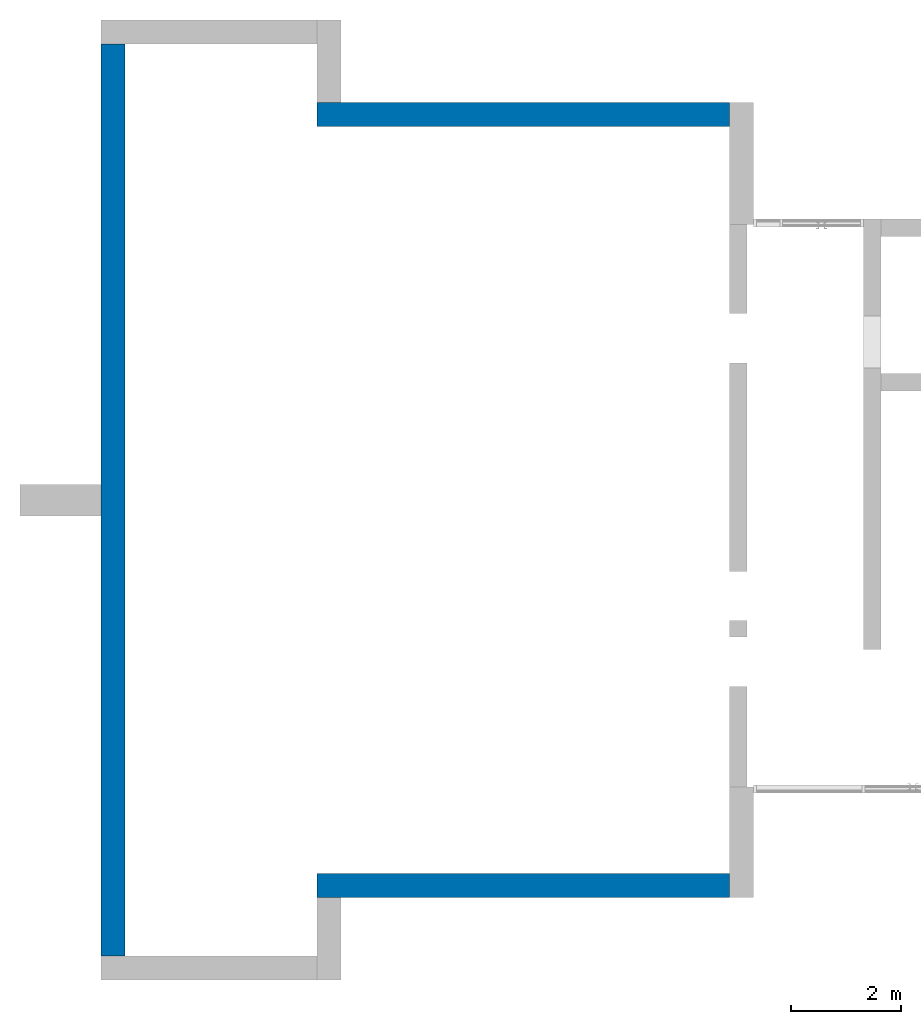
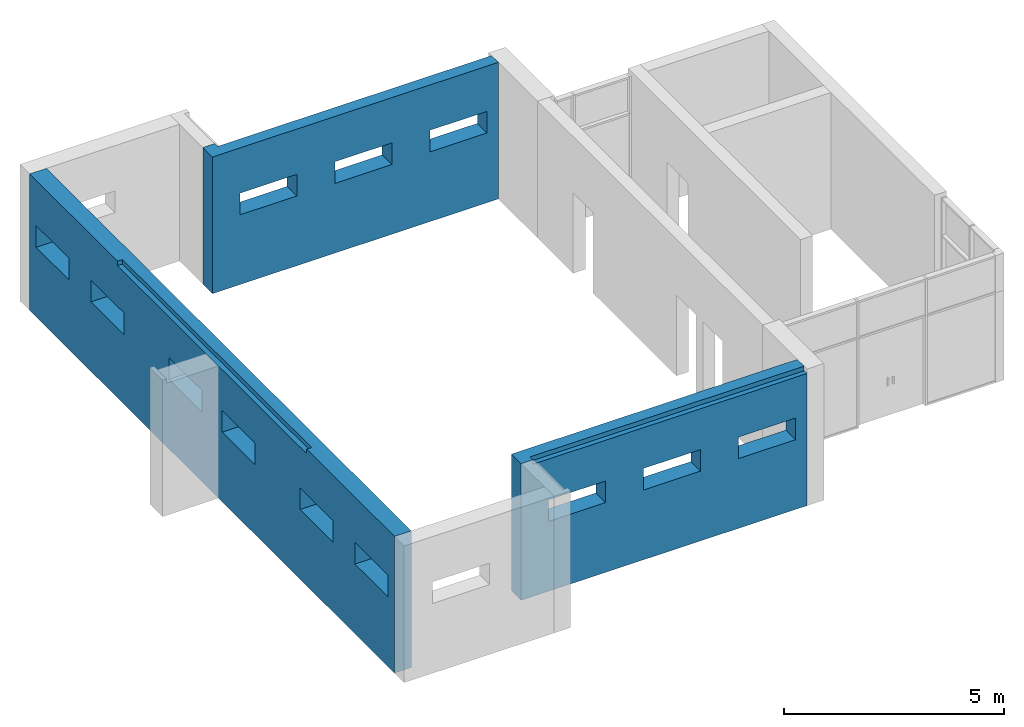
# One storey, part 3 of 4: 3 walls.
"""IFC2X3 building model written with IfcOpenShell, lengths in millimetres."""

import ifcopenshell
import ifcopenshell.guid

model = None  # the IFC model being written
_history = None  # IfcOwnerHistory: only IFC2X3 demands one
_inside = {}  # id of a spatial element -> (the spatial element, [elements in it])
_under = {}  # id of a project, library or spatial element -> (it, [spatial elements below it])
_declared = {}  # id of a project -> (the project, [libraries it declares])
_typed = {}  # id of a type object -> (the type object, [elements of that type])
_made_of = {}  # id of a material, layer set ... -> (it, [elements and type objects made of it])


def new_model(schema):
    """Start an empty IFC model of exactly this schema.

    Asked for "IFC4X3", IfcOpenShell would pick the latest addendum, in which some entities
    have other attributes; the version numbers below select the first issue.
    IFC2X3 requires an IfcOwnerHistory on every rooted entity: one is made here for all.
    """
    global model, _history
    if schema == "IFC4X3":
        model = ifcopenshell.file(schema_version=(4, 3, 0, 0))
    else:
        model = ifcopenshell.file(schema=schema)
    _inside.clear()
    _under.clear()
    _declared.clear()
    _typed.clear()
    _made_of.clear()
    _history = None
    if model.schema == "IFC2X3":
        org = make("IfcOrganization", Name="unknown")
        user = make(
            "IfcPersonAndOrganization",
            ThePerson=make("IfcPerson", FamilyName="unknown"),
            TheOrganization=org,
        )
        app = make(
            "IfcApplication",
            ApplicationDeveloper=org,
            Version="unknown",
            ApplicationFullName="unknown",
            ApplicationIdentifier="unknown",
        )
        _history = make(
            "IfcOwnerHistory",
            OwningUser=user,
            OwningApplication=app,
            ChangeAction="ADDED",
            CreationDate=0,
        )
    return model


def make(cls, **values):
    """One entity of the class cls with the attributes given. An attribute that is None is left unset."""
    return model.create_entity(
        cls, **{name: value for name, value in values.items() if value is not None}
    )


def entity(cls, *values):
    """Any entity or typed value of the class cls, its attributes in the order of the schema. None: left unset."""
    e = model.create_entity(cls)
    for i, value in enumerate(values):
        if value is not None:
            e[i] = value
    return e


def rooted(cls, **values):
    """An entity with a GlobalId (a new one), such as an element, a storey or a relation."""
    return make(cls, GlobalId=ifcopenshell.guid.new(), OwnerHistory=_history, **values)


def si_unit(unit_type, name, prefix=None):
    """IfcSIUnit, for example si_unit("LENGTHUNIT", "METRE", prefix="MILLI")."""
    return make("IfcSIUnit", UnitType=unit_type, Prefix=prefix, Name=name)


def converted_unit(unit_type, name, factor, base, dimensions=None, offset=None):
    """IfcConversionBasedUnit, such as the inch: factor (a typed value) times the base unit."""
    return make(
        "IfcConversionBasedUnit"
        if offset is None
        else "IfcConversionBasedUnitWithOffset",
        ConversionOffset=offset,
        Dimensions=None
        if dimensions is None
        else entity("IfcDimensionalExponents", *dimensions),
        UnitType=unit_type,
        Name=name,
        ConversionFactor=make(
            "IfcMeasureWithUnit", ValueComponent=factor, UnitComponent=base
        ),
    )


def derived_unit(unit_type, elements):
    """IfcDerivedUnit: a product of units, each with its exponent."""
    return make(
        "IfcDerivedUnit",
        Elements=[
            make("IfcDerivedUnitElement", Unit=unit, Exponent=power)
            for unit, power in elements
        ],
        UnitType=unit_type,
    )


def assignment(units):
    """IfcUnitAssignment: the units of a project."""
    return None if units is None else make("IfcUnitAssignment", Units=units)


def point(xyz):
    """IfcCartesianPoint."""
    return None if xyz is None else make("IfcCartesianPoint", Coordinates=xyz)


def direction(xyz):
    """IfcDirection."""
    return None if xyz is None else make("IfcDirection", DirectionRatios=xyz)


def frame(location, z_axis=None, x_axis=None):
    """IfcAxis2Placement3D, a coordinate frame: its origin and axes. An axis left out is left unset."""
    return make(
        "IfcAxis2Placement3D",
        Location=point(location),
        Axis=direction(z_axis),
        RefDirection=direction(x_axis),
    )


def origin():
    """The frame at (0, 0, 0) with its axes left unset."""
    return frame((0.0, 0.0, 0.0))


def place(relative_to, where):
    """IfcLocalPlacement: puts the frame where relative to a parent placement (None: the world)."""
    return make(
        "IfcLocalPlacement", PlacementRelTo=relative_to, RelativePlacement=where
    )


def context(
    kind, dimensions, precision=None, world=None, true_north=None, identifier=None
):
    """IfcGeometricRepresentationContext, for example the 3D "Model" context."""
    return make(
        "IfcGeometricRepresentationContext",
        ContextIdentifier=identifier,
        ContextType=kind,
        CoordinateSpaceDimension=dimensions,
        Precision=precision,
        WorldCoordinateSystem=world,
        TrueNorth=true_north,
    )


def subcontext(parent, identifier, kind, view, scale=None):
    """IfcGeometricRepresentationSubContext, for example "Body" below "Model"."""
    return make(
        "IfcGeometricRepresentationSubContext",
        ContextIdentifier=identifier,
        ContextType=kind,
        ParentContext=parent,
        TargetScale=scale,
        TargetView=view,
    )


def project(units=None, contexts=None):
    """IfcProject with its units and contexts."""
    return rooted(
        "IfcProject",
        Name="project",
        RepresentationContexts=contexts,
        UnitsInContext=assignment(units),
    )


def spatial(cls, under=None, at=None, **own):
    """A site, building, storey or space (cls), placed at a placement, below another one or the project."""
    s = rooted(cls, ObjectPlacement=at, **own)
    if under is not None:
        _under.setdefault(under.id(), (under, []))[1].append(s)
    return s


def faces_of(points, faces, orient=None, outer=None):
    """IfcFace entities. A face is a list of loops; a loop is a list of indices into points, from 0.

    orient and outer hold one flag for each loop. By default every Orientation is true, the
    first loop of a face is its IfcFaceOuterBound and the others are IfcFaceBound.
    """
    made = []
    for i, loops in enumerate(faces):
        bounds = []
        for j, loop in enumerate(loops):
            is_outer = j == 0 if outer is None else outer[i][j]
            bounds.append(
                make(
                    "IfcFaceOuterBound" if is_outer else "IfcFaceBound",
                    Bound=make("IfcPolyLoop", Polygon=[points[k] for k in loop]),
                    Orientation=True if orient is None else orient[i][j],
                )
            )
        made.append(make("IfcFace", Bounds=bounds))
    return made


def faceted_brep(points, faces, orient=None, outer=None, voids=None):
    """IfcFacetedBrep: a solid bounded by flat faces; with voids (closed shells), ...WithVoids."""
    shared = [point(p) for p in points]
    hull = make("IfcClosedShell", CfsFaces=faces_of(shared, faces, orient, outer))
    if voids is None:
        return make("IfcFacetedBrep", Outer=hull)
    return make(
        "IfcFacetedBrepWithVoids",
        Outer=hull,
        Voids=[
            make(cls, CfsFaces=faces_of(shared, fs, o, b)) for cls, fs, o, b in voids
        ],
    )


def shape(context_of_items, identifier, shape_type, items):
    """IfcShapeRepresentation: the items that make up one representation, for example the "Body"."""
    return make(
        "IfcShapeRepresentation",
        ContextOfItems=context_of_items,
        RepresentationIdentifier=identifier,
        RepresentationType=shape_type,
        Items=items,
    )


def material(Name=None, Category=None):
    """IfcMaterial."""
    return make("IfcMaterial", Name=Name, Category=Category)


def layer(
    of_material, thickness, ventilated=None, Name=None, Category=None, Priority=None
):
    """IfcMaterialLayer: one layer of a wall or slab, of a material (None: an air gap)."""
    return make(
        "IfcMaterialLayer",
        Material=of_material,
        LayerThickness=thickness,
        IsVentilated=ventilated,
        Name=Name,
        Category=Category,
        Priority=Priority,
    )


def layer_set(layers, Name=None):
    """IfcMaterialLayerSet."""
    return make("IfcMaterialLayerSet", MaterialLayers=layers, LayerSetName=Name)


def made_of(thing, what):
    """Note that an element or type object is made of a material, layer set ...; save() writes the relation."""
    if what is not None:
        _made_of.setdefault(what.id(), (what, []))[1].append(thing)
    return thing


def type_object(cls, material=None, **own):
    """A type object (cls), such as IfcWallType, which elements share."""
    return made_of(rooted(cls, **own), material)


def element(
    cls,
    number,
    at=None,
    inside=None,
    cuts=None,
    type_object=None,
    material=None,
    context=None,
    identifier="Body",
    shape_type=None,
    held_by="IfcProductDefinitionShape",
    body=None,
    shapes=None,
    **own,
):
    """One element of the class cls, such as IfcWall. Its Tag is "e" and its number.

    at: its placement. inside: the storey or other place that contains it. cuts: it is an
    opening in that element (IfcRelVoidsElement). A single representation is given by context,
    identifier, shape_type and body (its items); several are given by shapes. held_by: the class
    of the entity that holds the representations. save() writes the other relations.
    """
    e = rooted(cls, Tag="e%d" % number, ObjectPlacement=at, **own)
    if body is not None:
        shapes = [shape(context, identifier, shape_type, body)]
    if shapes is not None:
        e.Representation = make(held_by, Representations=shapes)
    if inside is not None:
        _inside.setdefault(inside.id(), (inside, []))[1].append(e)
    if cuts is not None:
        rooted(
            "IfcRelVoidsElement", RelatingBuildingElement=cuts, RelatedOpeningElement=e
        )
    if type_object is not None:
        _typed.setdefault(type_object.id(), (type_object, []))[1].append(e)
    return made_of(e, material)


def aggregate(whole, parts):
    """IfcRelAggregates: a whole, such as a stair, and the parts it consists of."""
    return rooted("IfcRelAggregates", RelatingObject=whole, RelatedObjects=parts)


def save(model, path):
    """Write the relations noted so far, then the file.

    IfcRelAggregates (storeys below a building ...), IfcRelContainedInSpatialStructure (elements
    in a storey), IfcRelDefinesByType, IfcRelAssociatesMaterial and IfcRelDeclares: one each for
    every whole, place, type object, material and project.
    """
    for whole, parts in _under.values():
        aggregate(whole, parts)
    for where, things in _inside.values():
        rooted(
            "IfcRelContainedInSpatialStructure",
            RelatedElements=things,
            RelatingStructure=where,
        )
    for kind, things in _typed.values():
        rooted("IfcRelDefinesByType", RelatedObjects=things, RelatingType=kind)
    for what, things in _made_of.values():
        rooted("IfcRelAssociatesMaterial", RelatedObjects=things, RelatingMaterial=what)
    for by, libraries in _declared.values():
        rooted("IfcRelDeclares", RelatingContext=by, RelatedDefinitions=libraries)
    model.write(path)


model = new_model("IFC2X3")

# Units and contexts
model_context = context("Model", 3, precision=0.01, world=origin(), true_north=direction((6.12303176911189e-17, 1.0)))
body_context = subcontext(model_context, "Body", "Model", "MODEL_VIEW")
ifc_project = project(units=[si_unit("LENGTHUNIT", "METRE", prefix="MILLI"), si_unit("AREAUNIT", "SQUARE_METRE"), si_unit("VOLUMEUNIT", "CUBIC_METRE"), converted_unit("PLANEANGLEUNIT", "DEGREE", entity("IfcRatioMeasure", 0.0174532925199433), si_unit("PLANEANGLEUNIT", "RADIAN"), dimensions=[0, 0, 0, 0, 0, 0, 0]), si_unit("MASSUNIT", "GRAM", prefix="KILO"), derived_unit("MASSDENSITYUNIT", [(si_unit("MASSUNIT", "GRAM", prefix="KILO"), 1), (si_unit("LENGTHUNIT", "METRE"), -3)]), si_unit("TIMEUNIT", "SECOND"), si_unit("FREQUENCYUNIT", "HERTZ"), si_unit("THERMODYNAMICTEMPERATUREUNIT", "DEGREE_CELSIUS"), derived_unit("THERMALTRANSMITTANCEUNIT", [(si_unit("MASSUNIT", "GRAM", prefix="KILO"), 1), (si_unit("THERMODYNAMICTEMPERATUREUNIT", "KELVIN"), -1), (si_unit("TIMEUNIT", "SECOND"), -3)]), derived_unit("VOLUMETRICFLOWRATEUNIT", [(si_unit("LENGTHUNIT", "METRE"), 3), (si_unit("TIMEUNIT", "SECOND"), -1)]), si_unit("ELECTRICCURRENTUNIT", "AMPERE"), si_unit("ELECTRICVOLTAGEUNIT", "VOLT"), si_unit("POWERUNIT", "WATT"), si_unit("FORCEUNIT", "NEWTON", prefix="KILO"), si_unit("ILLUMINANCEUNIT", "LUX"), si_unit("LUMINOUSFLUXUNIT", "LUMEN"), si_unit("LUMINOUSINTENSITYUNIT", "CANDELA"), derived_unit("USERDEFINED", [(si_unit("MASSUNIT", "GRAM", prefix="KILO"), -1), (si_unit("LENGTHUNIT", "METRE"), -2), (si_unit("TIMEUNIT", "SECOND"), 3), (si_unit("LUMINOUSFLUXUNIT", "LUMEN"), 1)]), derived_unit("LINEARVELOCITYUNIT", [(si_unit("LENGTHUNIT", "METRE"), 1), (si_unit("TIMEUNIT", "SECOND"), -1)]), si_unit("PRESSUREUNIT", "PASCAL"), derived_unit("USERDEFINED", [(si_unit("LENGTHUNIT", "METRE"), -2), (si_unit("MASSUNIT", "GRAM", prefix="KILO"), 1), (si_unit("TIMEUNIT", "SECOND"), -2)])], contexts=[model_context])

# Site, building, storey
site_placement = place(None, origin())
site = spatial("IfcSite", under=ifc_project, at=site_placement, CompositionType="ELEMENT")
building_placement = place(site_placement, origin())
building = spatial("IfcBuilding", under=site, at=building_placement, CompositionType="ELEMENT")
storey_placement = place(building_placement, origin())
storey = spatial("IfcBuildingStorey", under=building, at=storey_placement, Name="00 Ground level", CompositionType="ELEMENT", Elevation=0.0)

# Walls
ifc_material_1 = material(Name="03")
ifc_layer_1 = layer(ifc_material_1, 10.0)
ifc_material_2 = material()
ifc_layer_2 = layer(ifc_material_2, 120.0)
ifc_material_3 = material()
ifc_layer_3 = layer(ifc_material_3, 300.0)
ifc_layer_4 = layer(ifc_material_1, 10.0)
ifc_layer_set = layer_set([ifc_layer_1, ifc_layer_2, ifc_layer_3, ifc_layer_4], Name="Basic Wall:00_fal+12 cm")
wall_type = type_object("IfcWallType", Name="Basic Wall:00_fal+12 cm", PredefinedType="STANDARD", material=ifc_layer_set)
wall_1_placement = place(storey_placement, frame((28503.4900708518, -75861.2395851399, -140.0), z_axis=(0.0, 0.0, 1.0), x_axis=(-1.0, 0.0, 0.0)))
element("IfcWall", 1, at=wall_1_placement, inside=storey, type_object=wall_type, Name="Basic Wall:00_fal+12 cm", ObjectType="Basic Wall:00_fal+12 cm", context=body_context, shape_type="Brep", body=[
    faceted_brep([(0.0, -220.0, 0.0), (7200.0, -220.0, 0.0), (7520.0, -220.0, 0.0), (7520.0, -220.0, 3800.0), (7200.0, -220.0, 3800.0), (0.0, -220.0, 3800.0), (1800.0, -220.0, 2540.0), (1800.0, -220.0, 1940.0), (300.0, -220.0, 1940.0), (300.0, -220.0, 2540.0), (4300.0, -220.0, 2540.0), (4300.0, -220.0, 1940.0), (2800.0, -220.0, 1940.0), (2800.0, -220.0, 2540.0), (6800.0, -220.0, 2540.0), (6800.0, -220.0, 1940.0), (5300.0, -220.0, 1940.0), (5300.0, -220.0, 2540.0), (7520.0, 220.0, 0.0), (7080.0, 220.0, 0.0), (0.0, 220.0, 0.0), (0.0, 220.0, 3675.0), (7210.0, 220.0, 3675.0), (7210.0, 220.0, 3800.0), (7520.0, 220.0, 3800.0), (1800.0, 220.0, 1940.0), (1800.0, 220.0, 2540.0), (300.0, 220.0, 2540.0), (300.0, 220.0, 1940.0), (4300.0, 220.0, 1940.0), (4300.0, 220.0, 2540.0), (2800.0, 220.0, 2540.0), (2800.0, 220.0, 1940.0), (6800.0, 220.0, 1940.0), (6800.0, 220.0, 2540.0), (5300.0, 220.0, 2540.0), (5300.0, 220.0, 1940.0), (7210.0, 90.0, 3800.0), (0.0, 90.0, 3800.0), (0.0, 90.0, 3675.0), (7210.0, 90.0, 3675.0)], [[[0, 1, 2, 3, 4, 5], [6, 7, 8, 9], [10, 11, 12, 13], [14, 15, 16, 17]], [[18, 19, 20, 21, 22, 23, 24], [25, 26, 27, 28], [29, 30, 31, 32], [33, 34, 35, 36]], [[2, 1, 0, 20, 19, 18]], [[5, 4, 3, 24, 23, 37, 38]], [[3, 2, 18, 24]], [[20, 0, 5, 38, 39, 21]], [[40, 22, 21, 39]], [[37, 40, 39, 38]], [[40, 37, 23, 22]], [[26, 25, 7, 6]], [[27, 26, 6, 9]], [[28, 27, 9, 8]], [[25, 28, 8, 7]], [[30, 29, 11, 10]], [[31, 30, 10, 13]], [[32, 31, 13, 12]], [[29, 32, 12, 11]], [[34, 33, 15, 14]], [[35, 34, 14, 17]], [[36, 35, 17, 16]], [[33, 36, 16, 15]]]),
])
wall_2_placement = place(storey_placement, frame((17263.4900708518, -77141.2395851399, -140.0), z_axis=(0.0, 0.0, 1.0), x_axis=(0.0, 1.0, 0.0)))
element("IfcWall", 2, at=wall_2_placement, inside=storey, type_object=wall_type, Name="Basic Wall:00_fal+12 cm", ObjectType="Basic Wall:00_fal+12 cm", context=body_context, shape_type="Brep", body=[
    faceted_brep([(0.0, -220.0, 0.0), (5910.0, -220.0, 0.0), (6010.0, -220.0, 0.0), (8150.0, -220.0, 0.0), (8470.0, -220.0, 0.0), (10610.0, -220.0, 0.0), (10710.0, -220.0, 0.0), (16620.0, -220.0, 0.0), (16620.0, -220.0, 3800.0), (10710.0, -220.0, 3800.0), (10610.0, -220.0, 3800.0), (8470.0, -220.0, 3800.0), (8150.0, -220.0, 3800.0), (6010.0, -220.0, 3800.0), (5910.0, -220.0, 3800.0), (0.0, -220.0, 3800.0), (7850.0, -220.0, 2540.0), (7850.0, -220.0, 1940.0), (6350.0, -220.0, 1940.0), (6350.0, -220.0, 2540.0), (1800.0, -220.0, 2540.0), (1800.0, -220.0, 1940.0), (300.0, -220.0, 1940.0), (300.0, -220.0, 2540.0), (4300.0, -220.0, 2540.0), (4300.0, -220.0, 1940.0), (2800.0, -220.0, 1940.0), (2800.0, -220.0, 2540.0), (12320.0, -220.0, 1940.0), (12320.0, -220.0, 2540.0), (13820.0, -220.0, 2540.0), (13820.0, -220.0, 1940.0), (14820.0, -220.0, 1940.0), (14820.0, -220.0, 2540.0), (16320.0, -220.0, 2540.0), (16320.0, -220.0, 1940.0), (8770.0, -220.0, 1940.0), (8770.0, -220.0, 2540.0), (10270.0, -220.0, 2540.0), (10270.0, -220.0, 1940.0), (16620.0, 220.0, 0.0), (8590.0, 220.0, 0.0), (8020.0, 220.0, 0.0), (0.0, 220.0, 0.0), (0.0, 220.0, 3800.0), (4000.0, 220.0, 3800.0), (4000.0, 220.0, 3675.0), (12620.0, 220.0, 3675.0), (12620.0, 220.0, 3800.0), (16620.0, 220.0, 3800.0), (7850.0, 220.0, 1940.0), (7850.0, 220.0, 2540.0), (6350.0, 220.0, 2540.0), (6350.0, 220.0, 1940.0), (1800.0, 220.0, 1940.0), (1800.0, 220.0, 2540.0), (300.0, 220.0, 2540.0), (300.0, 220.0, 1940.0), (4300.0, 220.0, 1940.0), (4300.0, 220.0, 2540.0), (2800.0, 220.0, 2540.0), (2800.0, 220.0, 1940.0), (12320.0, 220.0, 2540.0), (12320.0, 220.0, 1940.0), (13820.0, 220.0, 1940.0), (13820.0, 220.0, 2540.0), (14820.0, 220.0, 2540.0), (14820.0, 220.0, 1940.0), (16320.0, 220.0, 1940.0), (16320.0, 220.0, 2540.0), (8770.0, 220.0, 2540.0), (8770.0, 220.0, 1940.0), (10270.0, 220.0, 1940.0), (10270.0, 220.0, 2540.0), (16620.0, 90.0, 3800.0), (12620.0, 90.0, 3800.0), (4000.0, 90.0, 3800.0), (0.0, 90.0, 3800.0), (4000.0, 90.0, 3675.0), (12620.0, 90.0, 3675.0)], [[[0, 1, 2, 3, 4, 5, 6, 7, 8, 9, 10, 11, 12, 13, 14, 15], [16, 17, 18, 19], [20, 21, 22, 23], [24, 25, 26, 27], [28, 29, 30, 31], [32, 33, 34, 35], [36, 37, 38, 39]], [[40, 41, 42, 43, 44, 45, 46, 47, 48, 49], [50, 51, 52, 53], [54, 55, 56, 57], [58, 59, 60, 61], [62, 63, 64, 65], [66, 67, 68, 69], [70, 71, 72, 73]], [[7, 6, 5, 4, 3, 2, 1, 0, 43, 42, 41, 40]], [[15, 14, 13, 12, 11, 10, 9, 8, 74, 49, 48, 75, 76, 45, 44, 77]], [[0, 15, 77, 44, 43]], [[8, 7, 40, 49, 74]], [[51, 50, 17, 16]], [[52, 51, 16, 19]], [[53, 52, 19, 18]], [[50, 53, 18, 17]], [[55, 54, 21, 20]], [[56, 55, 20, 23]], [[57, 56, 23, 22]], [[54, 57, 22, 21]], [[59, 58, 25, 24]], [[60, 59, 24, 27]], [[61, 60, 27, 26]], [[58, 61, 26, 25]], [[29, 28, 63, 62]], [[30, 29, 62, 65]], [[31, 30, 65, 64]], [[28, 31, 64, 63]], [[33, 32, 67, 66]], [[34, 33, 66, 69]], [[35, 34, 69, 68]], [[32, 35, 68, 67]], [[37, 36, 71, 70]], [[38, 37, 70, 73]], [[39, 38, 73, 72]], [[36, 39, 72, 71]], [[78, 79, 47, 46]], [[79, 75, 48, 47]], [[79, 78, 76, 75]], [[76, 78, 46, 45]]]),
])
wall_3_placement = place(storey_placement, frame((28503.4900708518, -61801.23958514, -140.0), z_axis=(0.0, 0.0, 1.0), x_axis=(-1.0, 0.0, 0.0)))
element("IfcWall", 3, at=wall_3_placement, inside=storey, type_object=wall_type, Name="Basic Wall:00_fal+12 cm", ObjectType="Basic Wall:00_fal+12 cm", context=body_context, shape_type="Brep", body=[
    faceted_brep([(0.0, -220.0, 0.0), (7080.0, -220.0, 0.0), (7520.0, -220.0, 0.0), (7520.0, -220.0, 3800.0), (7210.0, -220.0, 3800.0), (7210.0, -220.0, 3675.0), (0.0, -220.0, 3675.0), (6800.0, -220.0, 2540.0), (6800.0, -220.0, 1940.0), (5300.0, -220.0, 1940.0), (5300.0, -220.0, 2540.0), (4300.0, -220.0, 2540.0), (4300.0, -220.0, 1940.0), (2800.0, -220.0, 1940.0), (2800.0, -220.0, 2540.0), (1800.0, -220.0, 2540.0), (1800.0, -220.0, 1940.0), (300.0, -220.0, 1940.0), (300.0, -220.0, 2540.0), (7520.0, 220.0, 0.0), (7200.0, 220.0, 0.0), (0.0, 220.0, 0.0), (0.0, 220.0, 3800.0), (300.0, 220.0, 3800.0), (6700.0, 220.0, 3800.0), (7200.0, 220.0, 3800.0), (7520.0, 220.0, 3800.0), (6800.0, 220.0, 1940.0), (6800.0, 220.0, 2540.0), (5300.0, 220.0, 2540.0), (5300.0, 220.0, 1940.0), (4300.0, 220.0, 1940.0), (4300.0, 220.0, 2540.0), (2800.0, 220.0, 2540.0), (2800.0, 220.0, 1940.0), (1800.0, 220.0, 1940.0), (1800.0, 220.0, 2540.0), (300.0, 220.0, 2540.0), (300.0, 220.0, 1940.0), (0.0, -90.0, 3800.0), (7210.0, -90.0, 3800.0), (0.0, -90.0, 3675.0), (7210.0, -90.0, 3675.0)], [[[0, 1, 2, 3, 4, 5, 6], [7, 8, 9, 10], [11, 12, 13, 14], [15, 16, 17, 18]], [[19, 20, 21, 22, 23, 24, 25, 26], [27, 28, 29, 30], [31, 32, 33, 34], [35, 36, 37, 38]], [[2, 1, 0, 21, 20, 19]], [[26, 25, 24, 23, 22, 39, 40, 4, 3]], [[3, 2, 19, 26]], [[22, 21, 0, 6, 41, 39]], [[42, 41, 6, 5]], [[28, 27, 8, 7]], [[29, 28, 7, 10]], [[30, 29, 10, 9]], [[27, 30, 9, 8]], [[32, 31, 12, 11]], [[33, 32, 11, 14]], [[34, 33, 14, 13]], [[31, 34, 13, 12]], [[36, 35, 16, 15]], [[37, 36, 15, 18]], [[38, 37, 18, 17]], [[35, 38, 17, 16]], [[40, 42, 5, 4]], [[42, 40, 39, 41]]]),
])

save(model, "model.ifc")
